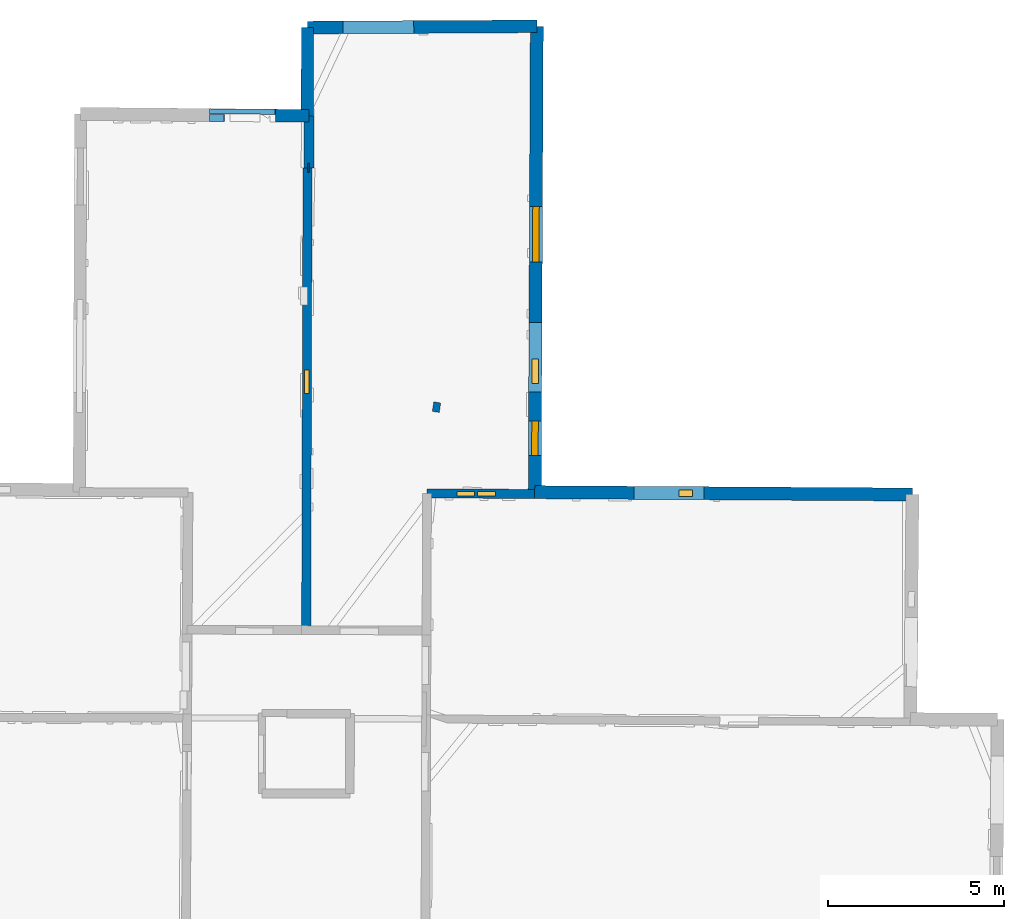
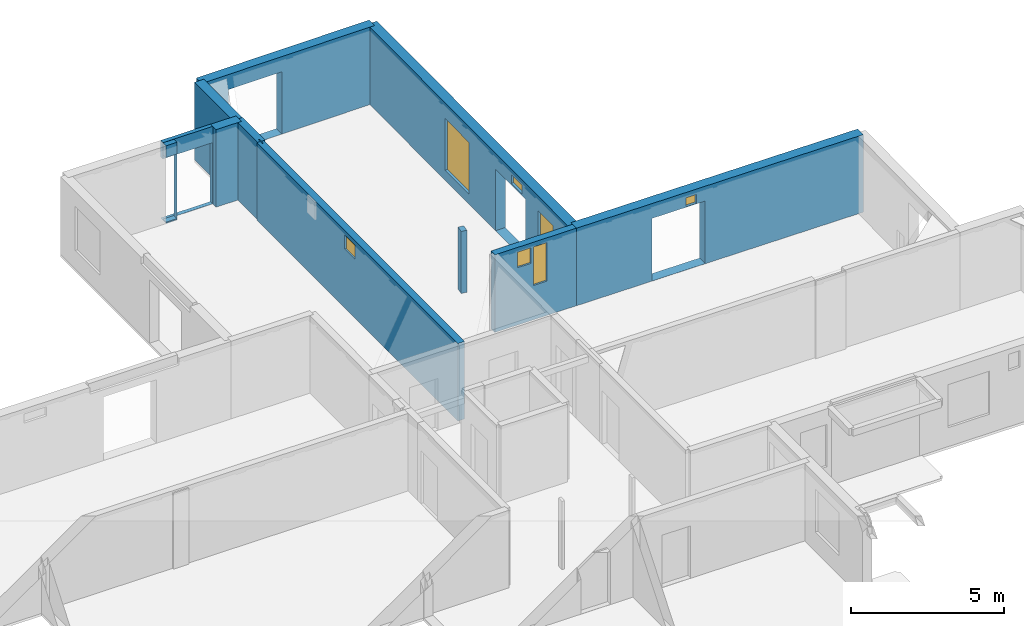
# One storey, part 10 of 15: 12 walls, 7 windows, 12 openings.
"""IFC2X3 building model written with IfcOpenShell, lengths in metres."""

from ifc_helpers import new_model, entity, si_unit, converted_unit, derived_unit, direction, frame, frame_2d, origin, origin_2d_with_axis, place, context, subcontext, project, spatial, polyline, rectangle, outline, extrude, source, transform, mapped, material, layer, layer_set, layer_usage, type_object, type_shapes, element, fill, save


model = new_model("IFC2X3")

# Units and contexts
model_context = context("Model", 3, precision=1e-05, world=origin(), true_north=direction((0.0, 1.0)))
body_context = subcontext(model_context, "Body", "Model", "MODEL_VIEW")
ifc_project = project(units=[si_unit("LENGTHUNIT", "METRE"), si_unit("AREAUNIT", "SQUARE_METRE"), si_unit("VOLUMEUNIT", "CUBIC_METRE"), converted_unit("PLANEANGLEUNIT", "DEGREE", entity("IfcRatioMeasure", 0.0174532925199433), si_unit("PLANEANGLEUNIT", "RADIAN"), dimensions=[0, 0, 0, 0, 0, 0, 0]), si_unit("MASSUNIT", "GRAM", prefix="KILO"), derived_unit("MASSDENSITYUNIT", [(si_unit("MASSUNIT", "GRAM", prefix="KILO"), 1), (si_unit("LENGTHUNIT", "METRE"), -3)]), derived_unit("MOMENTOFINERTIAUNIT", [(si_unit("LENGTHUNIT", "METRE"), 4)]), si_unit("TIMEUNIT", "SECOND"), si_unit("FREQUENCYUNIT", "HERTZ"), si_unit("THERMODYNAMICTEMPERATUREUNIT", "DEGREE_CELSIUS"), derived_unit("THERMALTRANSMITTANCEUNIT", [(si_unit("MASSUNIT", "GRAM", prefix="KILO"), 1), (si_unit("THERMODYNAMICTEMPERATUREUNIT", "KELVIN"), -1), (si_unit("TIMEUNIT", "SECOND"), -3)]), derived_unit("VOLUMETRICFLOWRATEUNIT", [(si_unit("LENGTHUNIT", "METRE"), 3), (si_unit("TIMEUNIT", "SECOND"), -1)]), si_unit("ELECTRICCURRENTUNIT", "AMPERE"), si_unit("ELECTRICVOLTAGEUNIT", "VOLT"), si_unit("POWERUNIT", "WATT"), si_unit("FORCEUNIT", "NEWTON", prefix="KILO"), si_unit("ILLUMINANCEUNIT", "LUX"), si_unit("LUMINOUSFLUXUNIT", "LUMEN"), si_unit("LUMINOUSINTENSITYUNIT", "CANDELA"), derived_unit("USERDEFINED", [(si_unit("MASSUNIT", "GRAM", prefix="KILO"), -1), (si_unit("LENGTHUNIT", "METRE"), -2), (si_unit("TIMEUNIT", "SECOND"), 3), (si_unit("LUMINOUSFLUXUNIT", "LUMEN"), 1)]), derived_unit("LINEARVELOCITYUNIT", [(si_unit("LENGTHUNIT", "METRE"), 1), (si_unit("TIMEUNIT", "SECOND"), -1)]), si_unit("PRESSUREUNIT", "PASCAL"), derived_unit("USERDEFINED", [(si_unit("LENGTHUNIT", "METRE"), -2), (si_unit("MASSUNIT", "GRAM", prefix="KILO"), 1), (si_unit("TIMEUNIT", "SECOND"), -2)]), derived_unit("LINEARFORCEUNIT", [(si_unit("MASSUNIT", "GRAM", prefix="KILO"), 1), (si_unit("LENGTHUNIT", "METRE"), 1), (si_unit("TIMEUNIT", "SECOND"), -2), (si_unit("LENGTHUNIT", "METRE"), -1)]), derived_unit("PLANARFORCEUNIT", [(si_unit("MASSUNIT", "GRAM", prefix="KILO"), 1), (si_unit("LENGTHUNIT", "METRE"), 1), (si_unit("TIMEUNIT", "SECOND"), -2), (si_unit("LENGTHUNIT", "METRE"), -2)])], contexts=[model_context])

# Site, building, storey
placement = place(None, origin())
site = spatial("IfcSite", under=ifc_project, at=placement, CompositionType="ELEMENT")
building = spatial("IfcBuilding", under=site, at=placement, CompositionType="ELEMENT")
storey_placement = place(placement, frame((0.0, 0.0, 2.3807327747345)))
storey = spatial("IfcBuildingStorey", under=building, at=storey_placement, Name="Level 2", CompositionType="ELEMENT", Elevation=2.3807327747345)

# Walls
ifc_material_1 = material(Name="Default wall")
ifc_layer_1 = layer(ifc_material_1, 0.349999994039536)
ifc_layer_set_1 = layer_set([ifc_layer_1], Name="wall_thickness_0.3500")
ifc_layer_usage_1 = layer_usage(ifc_layer_set_1, "AXIS2", "POSITIVE", -0.174999997019768)
wall_type_1 = type_object("IfcWallType", Name="wall_thickness_0.3500", PredefinedType="STANDARD", material=ifc_layer_set_1)
wall_1_placement = place(storey_placement, frame((6.40940972931042, 77.3030264539157, 0.0), z_axis=(0.0, 0.0, 1.0), x_axis=(-0.00343193730267941, -0.999994110885834, 0.0)))
element("IfcWallStandardCase", 1, at=wall_1_placement, inside=storey, type_object=wall_type_1, material=ifc_layer_usage_1, Name="Wall:833", ObjectType="Wall", context=body_context, shape_type="SweptSolid", body=[
    extrude(outline(polyline([(2.5126109274237, -0.174999997019768), (2.5126109274237, 0.174999997019768), (0.0, 0.174999997019768), (0.0, -0.174999997019768), (2.5126109274237, -0.174999997019768)])), origin(), (0.0, 0.0, 1.0), 3.08589615821838),
])
ifc_layer_2 = layer(ifc_material_1, 0.2)
ifc_layer_set_2 = layer_set([ifc_layer_2], Name="wall_thickness_0.2000")
ifc_layer_usage_2 = layer_usage(ifc_layer_set_2, "AXIS2", "POSITIVE", -0.1)
wall_type_2 = type_object("IfcWallType", Name="wall_thickness_0.2000", PredefinedType="STANDARD", material=ifc_layer_set_2)
wall_2_placement = place(storey_placement, frame((10.1019511417973, 66.6321647262947, 0.0), z_axis=(0.0, 0.0, 1.0), x_axis=(-0.144798683260253, -0.989461136844746, 0.0)))
element("IfcWallStandardCase", 2, at=wall_2_placement, inside=storey, type_object=wall_type_2, material=ifc_layer_usage_2, Name="Wall:792", ObjectType="Wall", context=body_context, shape_type="SweptSolid", body=[
    extrude(outline(polyline([(0.27500054911174, -0.1), (0.27500054911174, 0.1), (0.0, 0.1), (0.0, -0.1), (0.27500054911174, -0.1)])), origin(), (0.0, 0.0, 1.0), 2.46726727485657),
])

# Wall, opening, window
ifc_layer_3 = layer(ifc_material_1, 0.259999990463257)
ifc_layer_set_3 = layer_set([ifc_layer_3], Name="wall_thickness_0.2600")
ifc_layer_usage_3 = layer_usage(ifc_layer_set_3, "AXIS2", "POSITIVE", -0.129999995231628)
wall_type_3 = type_object("IfcWallType", Name="wall_thickness_0.2600", PredefinedType="STANDARD", material=ifc_layer_set_3)
wall_3_placement = place(storey_placement, frame((6.40879468991422, 73.3114207593688, 0.0), z_axis=(0.0, 0.0, 1.0), x_axis=(-0.00290263283017364, -0.999995787352453, 0.0)))
wall_3 = element("IfcWallStandardCase", 3, at=wall_3_placement, inside=storey, type_object=wall_type_3, material=ifc_layer_usage_3, Name="Wall:713", ObjectType="Wall", context=body_context, shape_type="SweptSolid", body=[
    extrude(outline(polyline([(13.163717410889, -0.129999995231628), (13.163717410889, 0.129999995231628), (0.0, 0.129999995231628), (0.0, -0.129999995231628), (13.163717410889, -0.129999995231628)])), origin(), (0.0, 0.0, 1.0), 3.08589615821838),
])
opening_1_placement = place(wall_3_placement, frame((5.75252668050183, -0.129999995231628, 2.3502676486969)))
opening_1 = element("IfcOpeningElement", 4, at=opening_1_placement, cuts=wall_3, Name="Opening : 675 x 570 : 454", ObjectType="Opening", context=body_context, shape_type="SweptSolid", body=[
    extrude(rectangle(XDim=0.675, YDim=0.57, at=frame_2d((0.285, 0.3375), x_axis=(0.0, 1.0))), frame((0.0, 0.0, 0.0), z_axis=(0.0, 1.0, 0.0), x_axis=(0.0, 0.0, 1.0)), (0.0, 0.0, 1.0), 0.259999990463257),
])
ifc_material_2 = material(Name="Window Default")
window_style_1 = type_object("IfcWindowStyle", Name="Window : 675 x 570mm", ConstructionType="NOTDEFINED", OperationType="NOTDEFINED", ParameterTakesPrecedence=False, Sizeable=False, material=ifc_material_2)
shared_shape_1 = source(origin(), body_context, "Body", "SweptSolid", [
    extrude(rectangle(XDim=0.129999995231628, YDim=0.675, at=origin_2d_with_axis()), frame((0.3375, 0.129999995231628, 0.0), z_axis=(0.0, 0.0, 1.0), x_axis=(0.0, 1.0, 0.0)), (0.0, 0.0, 1.0), 0.57),
])
type_shapes(window_style_1, [shared_shape_1])
window_1_placement = place(opening_1_placement, origin())
window_1 = element("IfcWindow", 5, at=window_1_placement, inside=storey, type_object=window_style_1, Name="Window : 675 x 570mm : 247", ObjectType="Window : 675 x 570mm", OverallHeight=0.57, OverallWidth=0.675, context=body_context, shape_type="MappedRepresentation", body=[
    mapped(shared_shape_1, transform((0.0, 0.0, 0.0), scale=1.0)),
])
fill(opening_1, window_1)

# Wall, openings, windows
wall_4_placement = place(storey_placement, frame((9.81067877445257, 64.0406864352747, 0.0), z_axis=(0.0, 0.0, 1.0), x_axis=(0.999987550143293, -0.00498994573263831, 0.0)))
wall_4 = element("IfcWallStandardCase", 6, at=wall_4_placement, inside=storey, type_object=wall_type_3, material=ifc_layer_usage_3, Name="Wall:818", ObjectType="Wall", context=body_context, shape_type="SweptSolid", body=[
    extrude(outline(polyline([(3.06708053548222, -0.129999995231628), (3.06708053548222, 0.129999995231628), (0.0, 0.129999995231628), (0.0, -0.129999995231628), (3.06708053548222, -0.129999995231628)])), origin(), (0.0, 0.0, 1.0), 3.08589615821838),
])
opening_2_placement = place(wall_4_placement, frame((0.85747689298459, -0.129999995231628, 2.27726721763611)))
opening_2 = element("IfcOpeningElement", 7, at=opening_2_placement, cuts=wall_4, Name="Opening : 495 x 620 : 521", ObjectType="Opening", context=body_context, shape_type="SweptSolid", body=[
    extrude(rectangle(XDim=0.495, YDim=0.62, at=frame_2d((0.31, 0.2475), x_axis=(0.0, 1.0))), frame((0.0, 0.0, 0.0), z_axis=(0.0, 1.0, 0.0), x_axis=(0.0, 0.0, 1.0)), (0.0, 0.0, 1.0), 0.259999990463257),
])
opening_3_placement = place(wall_4_placement, frame((1.44247278492697, -0.129999995231628, 1.36226773262024)))
opening_3 = element("IfcOpeningElement", 8, at=opening_3_placement, cuts=wall_4, Name="Opening : 505 x 1535 : 522", ObjectType="Opening", context=body_context, shape_type="SweptSolid", body=[
    extrude(rectangle(XDim=0.505, YDim=1.535, at=frame_2d((0.7675, 0.2525), x_axis=(0.0, 1.0))), frame((0.0, 0.0, 0.0), z_axis=(0.0, 1.0, 0.0), x_axis=(0.0, 0.0, 1.0)), (0.0, 0.0, 1.0), 0.259999990463257),
])
window_style_2 = type_object("IfcWindowStyle", Name="Window : 495 x 620mm", ConstructionType="NOTDEFINED", OperationType="NOTDEFINED", ParameterTakesPrecedence=False, Sizeable=False, material=ifc_material_2)
shared_shape_2 = source(origin(), body_context, "Body", "SweptSolid", [
    extrude(rectangle(XDim=0.129999995231628, YDim=0.495, at=origin_2d_with_axis()), frame((0.2475, 0.129999995231628, 0.0), z_axis=(0.0, 0.0, 1.0), x_axis=(0.0, 1.0, 0.0)), (0.0, 0.0, 1.0), 0.62),
])
type_shapes(window_style_2, [shared_shape_2])
window_2_placement = place(opening_2_placement, origin())
window_2 = element("IfcWindow", 9, at=window_2_placement, inside=storey, type_object=window_style_2, Name="Window : 495 x 620mm : 279", ObjectType="Window : 495 x 620mm", OverallHeight=0.62, OverallWidth=0.495, context=body_context, shape_type="MappedRepresentation", body=[
    mapped(shared_shape_2, transform((0.0, 0.0, 0.0), scale=1.0)),
])
fill(opening_2, window_2)
window_style_3 = type_object("IfcWindowStyle", Name="Window : 505 x 1535mm", ConstructionType="NOTDEFINED", OperationType="NOTDEFINED", ParameterTakesPrecedence=False, Sizeable=False, material=ifc_material_2)
shared_shape_3 = source(origin(), body_context, "Body", "SweptSolid", [
    extrude(rectangle(XDim=0.129999995231628, YDim=0.505, at=origin_2d_with_axis()), frame((0.2525, 0.129999995231628, 0.0), z_axis=(0.0, 0.0, 1.0), x_axis=(0.0, 1.0, 0.0)), (0.0, 0.0, 1.0), 1.535),
])
type_shapes(window_style_3, [shared_shape_3])
window_3_placement = place(opening_3_placement, origin())
window_3 = element("IfcWindow", 10, at=window_3_placement, inside=storey, type_object=window_style_3, Name="Window : 505 x 1535mm : 280", ObjectType="Window : 505 x 1535mm", OverallHeight=1.535, OverallWidth=0.505, context=body_context, shape_type="MappedRepresentation", body=[
    mapped(shared_shape_3, transform((0.0, 0.0, 0.0), scale=1.0)),
])
fill(opening_3, window_3)

ifc_layer_4 = layer(ifc_material_1, 0.370000004768372)
ifc_layer_set_4 = layer_set([ifc_layer_4], Name="wall_thickness_0.3700")
ifc_layer_usage_4 = layer_usage(ifc_layer_set_4, "AXIS2", "POSITIVE", -0.185000002384186)
wall_type_4 = type_object("IfcWallType", Name="wall_thickness_0.3700", PredefinedType="STANDARD", material=ifc_layer_set_4)
wall_5_placement = place(storey_placement, frame((12.9374793923585, 77.3395143958828, 0.0), z_axis=(0.0, 0.0, 1.0), x_axis=(-0.00448835509401027, -0.999989927283545, 0.0)))
wall_5 = element("IfcWallStandardCase", 11, at=wall_5_placement, inside=storey, type_object=wall_type_4, material=ifc_layer_usage_4, Name="Wall:689", ObjectType="Wall", context=body_context, shape_type="SweptSolid", body=[
    extrude(outline(polyline([(13.2641182858783, -0.185000002384186), (13.2641182858783, 0.185000002384186), (0.0, 0.185000002384186), (0.0, -0.185000002384186), (13.2641182858783, -0.185000002384186)])), origin(), (0.0, 0.0, 1.0), 3.08589615821838),
])
opening_4_placement = place(wall_5_placement, frame((8.43811901623632, -0.185000002384186, 0.00526785850524902)))
element("IfcOpeningElement", 12, at=opening_4_placement, cuts=wall_5, Name="Opening : 1975 x 2450 : 434", ObjectType="Opening", context=body_context, shape_type="SweptSolid", body=[
    extrude(rectangle(XDim=1.975, YDim=2.45, at=frame_2d((1.225, 0.9875), x_axis=(0.0, 1.0))), frame((0.0, 0.0, 0.0), z_axis=(0.0, 1.0, 0.0), x_axis=(0.0, 0.0, 1.0)), (0.0, 0.0, 1.0), 0.370000004768372),
])
opening_5_placement = place(wall_5_placement, frame((5.13312357018762, -0.185000002384186, 0.400267839431763)))
opening_5 = element("IfcOpeningElement", 13, at=opening_5_placement, cuts=wall_5, Name="Opening : 1580 x 2055 : 435", ObjectType="Opening", context=body_context, shape_type="SweptSolid", body=[
    extrude(rectangle(XDim=1.58, YDim=2.055, at=frame_2d((1.0275, 0.79), x_axis=(0.0, 1.0))), frame((0.0, 0.0, 0.0), z_axis=(0.0, 1.0, 0.0), x_axis=(0.0, 0.0, 1.0)), (0.0, 0.0, 1.0), 0.370000004768372),
])
opening_6_placement = place(wall_5_placement, frame((9.47597126912073, -0.185000002384186, 2.5212676525116)))
opening_6 = element("IfcOpeningElement", 14, at=opening_6_placement, cuts=wall_5, Name="Opening : 695 x 350 : 436", ObjectType="Opening", context=body_context, shape_type="SweptSolid", body=[
    extrude(rectangle(XDim=0.695, YDim=0.35, at=frame_2d((0.175, 0.3475), x_axis=(0.0, 1.0))), frame((0.0, 0.0, 0.0), z_axis=(0.0, 1.0, 0.0), x_axis=(0.0, 0.0, 1.0)), (0.0, 0.0, 1.0), 0.370000004768372),
])
opening_7_placement = place(wall_5_placement, frame((11.2381197545796, -0.185000002384186, 0.755267858505249)))
opening_7 = element("IfcOpeningElement", 15, at=opening_7_placement, cuts=wall_5, Name="Opening : 980 x 1745 : 437", ObjectType="Opening", context=body_context, shape_type="SweptSolid", body=[
    extrude(rectangle(XDim=0.98, YDim=1.745, at=frame_2d((0.8725, 0.49), x_axis=(0.0, 1.0))), frame((0.0, 0.0, 0.0), z_axis=(0.0, 1.0, 0.0), x_axis=(0.0, 0.0, 1.0)), (0.0, 0.0, 1.0), 0.370000004768372),
])
window_style_4 = type_object("IfcWindowStyle", Name="Window : 1580 x 2055mm", ConstructionType="NOTDEFINED", OperationType="NOTDEFINED", ParameterTakesPrecedence=False, Sizeable=False, material=ifc_material_2)
shared_shape_4 = source(origin(), body_context, "Body", "SweptSolid", [
    extrude(rectangle(XDim=0.185000002384186, YDim=1.58, at=origin_2d_with_axis()), frame((0.79, 0.185000002384186, 0.0), z_axis=(0.0, 0.0, 1.0), x_axis=(0.0, 1.0, 0.0)), (0.0, 0.0, 1.0), 2.055),
])
type_shapes(window_style_4, [shared_shape_4])
window_4_placement = place(opening_5_placement, origin())
window_4 = element("IfcWindow", 16, at=window_4_placement, inside=storey, type_object=window_style_4, Name="Window : 1580 x 2055mm : 236", ObjectType="Window : 1580 x 2055mm", OverallHeight=2.055, OverallWidth=1.58, context=body_context, shape_type="MappedRepresentation", body=[
    mapped(shared_shape_4, transform((0.0, 0.0, 0.0), scale=1.0)),
])
fill(opening_5, window_4)
window_style_5 = type_object("IfcWindowStyle", Name="Window : 695 x 350mm", ConstructionType="NOTDEFINED", OperationType="NOTDEFINED", ParameterTakesPrecedence=False, Sizeable=False, material=ifc_material_2)
shared_shape_5 = source(origin(), body_context, "Body", "SweptSolid", [
    extrude(rectangle(XDim=0.185000002384186, YDim=0.695, at=origin_2d_with_axis()), frame((0.3475, 0.185000002384186, 0.0), z_axis=(0.0, 0.0, 1.0), x_axis=(0.0, 1.0, 0.0)), (0.0, 0.0, 1.0), 0.35),
])
type_shapes(window_style_5, [shared_shape_5])
window_5_placement = place(opening_6_placement, origin())
window_5 = element("IfcWindow", 17, at=window_5_placement, inside=storey, type_object=window_style_5, Name="Window : 695 x 350mm : 237", ObjectType="Window : 695 x 350mm", OverallHeight=0.35, OverallWidth=0.695, context=body_context, shape_type="MappedRepresentation", body=[
    mapped(shared_shape_5, transform((0.0, 0.0, 0.0), scale=1.0)),
])
fill(opening_6, window_5)
window_style_6 = type_object("IfcWindowStyle", Name="Window : 980 x 1745mm", ConstructionType="NOTDEFINED", OperationType="NOTDEFINED", ParameterTakesPrecedence=False, Sizeable=False, material=ifc_material_2)
shared_shape_6 = source(origin(), body_context, "Body", "SweptSolid", [
    extrude(rectangle(XDim=0.185000002384186, YDim=0.98, at=origin_2d_with_axis()), frame((0.49, 0.185000002384186, 0.0), z_axis=(0.0, 0.0, 1.0), x_axis=(0.0, 1.0, 0.0)), (0.0, 0.0, 1.0), 1.745),
])
type_shapes(window_style_6, [shared_shape_6])
window_6_placement = place(opening_7_placement, origin())
window_6 = element("IfcWindow", 18, at=window_6_placement, inside=storey, type_object=window_style_6, Name="Window : 980 x 1745mm : 238", ObjectType="Window : 980 x 1745mm", OverallHeight=1.745, OverallWidth=0.98, context=body_context, shape_type="MappedRepresentation", body=[
    mapped(shared_shape_6, transform((0.0, 0.0, 0.0), scale=1.0)),
])
fill(opening_7, window_6)

# Wall, openings, window
wall_6_placement = place(storey_placement, frame((12.877946214726, 64.0755243825008, 0.0), z_axis=(0.0, 0.0, 1.0), x_axis=(0.999981333837981, -0.00610998982099564, 0.0)))
wall_6 = element("IfcWallStandardCase", 19, at=wall_6_placement, inside=storey, type_object=wall_type_4, material=ifc_layer_usage_4, Name="Wall:744", ObjectType="Wall", context=body_context, shape_type="SweptSolid", body=[
    extrude(outline(polyline([(10.7560906675092, -0.185000002384186), (10.7560906675092, 0.185000002384186), (0.0, 0.185000002384186), (0.0, -0.185000002384186), (10.7560906675092, -0.185000002384186)])), origin(), (0.0, 0.0, 1.0), 3.08589615821838),
])
opening_8_placement = place(wall_6_placement, frame((2.83135872644537, -0.185000002384186, 0.00526785850524902)))
element("IfcOpeningElement", 20, at=opening_8_placement, cuts=wall_6, Name="Opening : 1990 x 2490 : 477", ObjectType="Opening", context=body_context, shape_type="SweptSolid", body=[
    extrude(rectangle(XDim=1.99, YDim=2.49, at=frame_2d((1.245, 0.995), x_axis=(0.0, 1.0))), frame((0.0, 0.0, 0.0), z_axis=(0.0, 1.0, 0.0), x_axis=(0.0, 0.0, 1.0)), (0.0, 0.0, 1.0), 0.370000004768372),
])
opening_9_placement = place(wall_6_placement, frame((4.10189599998212, -0.185000002384186, 2.52126717567444)))
opening_9 = element("IfcOpeningElement", 21, at=opening_9_placement, cuts=wall_6, Name="Opening : 395 x 350 : 478", ObjectType="Opening", context=body_context, shape_type="SweptSolid", body=[
    extrude(rectangle(XDim=0.395, YDim=0.35, at=frame_2d((0.175, 0.1975), x_axis=(0.0, 1.0))), frame((0.0, 0.0, 0.0), z_axis=(0.0, 1.0, 0.0), x_axis=(0.0, 0.0, 1.0)), (0.0, 0.0, 1.0), 0.370000004768372),
])
window_style_7 = type_object("IfcWindowStyle", Name="Window : 395 x 350mm", ConstructionType="NOTDEFINED", OperationType="NOTDEFINED", ParameterTakesPrecedence=False, Sizeable=False, material=ifc_material_2)
shared_shape_7 = source(origin(), body_context, "Body", "SweptSolid", [
    extrude(rectangle(XDim=0.185000002384186, YDim=0.395, at=origin_2d_with_axis()), frame((0.1975, 0.185000002384186, 0.0), z_axis=(0.0, 0.0, 1.0), x_axis=(0.0, 1.0, 0.0)), (0.0, 0.0, 1.0), 0.35),
])
type_shapes(window_style_7, [shared_shape_7])
window_7_placement = place(opening_9_placement, origin())
window_7 = element("IfcWindow", 22, at=window_7_placement, inside=storey, type_object=window_style_7, Name="Window : 395 x 350mm : 259", ObjectType="Window : 395 x 350mm", OverallHeight=0.35, OverallWidth=0.395, context=body_context, shape_type="MappedRepresentation", body=[
    mapped(shared_shape_7, transform((0.0, 0.0, 0.0), scale=1.0)),
])
fill(opening_9, window_7)

# Wall, opening
ifc_layer_5 = layer(ifc_material_1, 0.200000002980232)
ifc_layer_set_5 = layer_set([ifc_layer_5], Name="wall_thickness_0.2000")
ifc_layer_usage_5 = layer_usage(ifc_layer_set_5, "AXIS2", "POSITIVE", -0.100000001490116)
wall_type_5 = type_object("IfcWallType", Name="wall_thickness_0.2000", PredefinedType="STANDARD", material=ifc_layer_set_5)
wall_7_placement = place(storey_placement, frame((3.62370016399202, 74.7358173775666, 0.0), z_axis=(0.0, 0.0, 1.0), x_axis=(0.999988906632864, -0.00471026657526411, 0.0)))
wall_7 = element("IfcWallStandardCase", 23, at=wall_7_placement, inside=storey, type_object=wall_type_5, material=ifc_layer_usage_5, Name="Wall:703", ObjectType="Wall", context=body_context, shape_type="SweptSolid", body=[
    extrude(outline(polyline([(0.416272489720247, -0.100000001490116), (0.416272489720247, 0.100000001490116), (0.0, 0.100000001490116), (0.0, -0.100000001490116), (0.416272489720247, -0.100000001490116)])), origin(), (0.0, 0.0, 1.0), 3.08589615821838),
])
opening_10_placement = place(wall_7_placement, frame((-0.293727416686131, -0.100000001490116, 0.0502669811248779)))
element("IfcOpeningElement", 24, at=opening_10_placement, cuts=wall_7, Name="Opening : 705 x 2570 : 444", ObjectType="Opening", context=body_context, shape_type="SweptSolid", body=[
    extrude(rectangle(XDim=0.705, YDim=2.57, at=frame_2d((1.285, 0.3525), x_axis=(0.0, 1.0))), frame((0.0, 0.0, 0.0), z_axis=(0.0, 1.0, 0.0), x_axis=(0.0, 0.0, 1.0)), (0.0, 0.0, 1.0), 0.200000002980232),
])

ifc_layer_6 = layer(ifc_material_1, 0.360000014305115)
ifc_layer_set_6 = layer_set([ifc_layer_6], Name="wall_thickness_0.3600")
ifc_layer_usage_6 = layer_usage(ifc_layer_set_6, "AXIS2", "POSITIVE", -0.180000007152557)
wall_type_6 = type_object("IfcWallType", Name="wall_thickness_0.3600", PredefinedType="STANDARD", material=ifc_layer_set_6)
wall_8_placement = place(storey_placement, frame((6.40940885447286, 77.303035030278, 0.0), z_axis=(0.0, 0.0, 1.0), x_axis=(0.999984383286354, 0.00558866561979852, 0.0)))
wall_8 = element("IfcWallStandardCase", 25, at=wall_8_placement, inside=storey, type_object=wall_type_6, material=ifc_layer_usage_6, Name="Wall:775", ObjectType="Wall", context=body_context, shape_type="SweptSolid", body=[
    extrude(outline(polyline([(6.52817096789426, -0.180000007152557), (6.52817096789426, 0.180000007152557), (0.0, 0.180000007152557), (0.0, -0.180000007152557), (6.52817096789426, -0.180000007152557)])), origin(), (0.0, 0.0, 1.0), 3.08589615821838),
])
opening_11_placement = place(wall_8_placement, frame((1.00414747691466, -0.180000007152557, 0.00526785850524902)))
element("IfcOpeningElement", 26, at=opening_11_placement, cuts=wall_8, Name="Opening : 2020 x 2480 : 489", ObjectType="Opening", context=body_context, shape_type="SweptSolid", body=[
    extrude(rectangle(XDim=2.02, YDim=2.48, at=frame_2d((1.24, 1.01), x_axis=(0.0, 1.0))), frame((0.0, 0.0, 0.0), z_axis=(0.0, 1.0, 0.0), x_axis=(0.0, 0.0, 1.0)), (0.0, 0.0, 1.0), 0.360000014305115),
])

# Wall
wall_9_placement = place(storey_placement, frame((5.49723104782976, 74.7988744400063, 0.0), z_axis=(0.0, 0.0, 1.0), x_axis=(0.999956402201162, -0.00933775652433995, 0.0)))
element("IfcWallStandardCase", 27, at=wall_9_placement, inside=storey, type_object=wall_type_6, material=ifc_layer_usage_6, Name="Wall:777", ObjectType="Wall", context=body_context, shape_type="SweptSolid", body=[
    extrude(outline(polyline([(0.954311968755246, -0.180000007152557), (0.954311968755246, 0.180000007152557), (0.0, 0.180000007152557), (0.0, -0.180000007152557), (0.954311968755246, -0.180000007152557)])), origin(), (0.0, 0.0, 1.0), 3.08589615821838),
])

# Wall, opening
ifc_layer_7 = layer(ifc_material_1, 0.150000005960464)
ifc_layer_set_7 = layer_set([ifc_layer_7], Name="wall_thickness_0.1500")
ifc_layer_usage_7 = layer_usage(ifc_layer_set_7, "AXIS2", "POSITIVE", -0.0750000029802322)
wall_type_7 = type_object("IfcWallType", Name="wall_thickness_0.1500", PredefinedType="STANDARD", material=ifc_layer_set_7)
wall_10_placement = place(storey_placement, frame((3.62455987789292, 74.9177955053171, 0.0), z_axis=(0.0, 0.0, 1.0), x_axis=(0.999989021529408, -0.00468581056570425, 0.0)))
wall_10 = element("IfcWallStandardCase", 28, at=wall_10_placement, inside=storey, type_object=wall_type_7, material=ifc_layer_usage_7, Name="Wall:766", ObjectType="Wall", context=body_context, shape_type="SweptSolid", body=[
    extrude(outline(polyline([(1.87404782637622, -0.0750000029802322), (1.87404782637622, 0.0750000029802322), (0.0, 0.0750000029802322), (0.0, -0.0750000029802322), (1.87404782637622, -0.0750000029802322)])), origin(), (0.0, 0.0, 1.0), 3.08589615821838),
])
opening_12_placement = place(wall_10_placement, frame((-0.119689321577622, -0.0750000029802322, 0.00526785850524902)))
element("IfcOpeningElement", 29, at=opening_12_placement, cuts=wall_10, Name="Opening : 1980 x 2435 : 486", ObjectType="Opening", context=body_context, shape_type="SweptSolid", body=[
    extrude(rectangle(XDim=1.98, YDim=2.435, at=frame_2d((1.2175, 0.99), x_axis=(0.0, 1.0))), frame((0.0, 0.0, 0.0), z_axis=(0.0, 1.0, 0.0), x_axis=(0.0, 0.0, 1.0)), (0.0, 0.0, 1.0), 0.150000005960464),
])

# Walls
ifc_layer_8 = layer(ifc_material_1, 0.245675176382065)
ifc_layer_set_8 = layer_set([ifc_layer_8], Name="wall_thickness_0.2457")
ifc_layer_usage_8 = layer_usage(ifc_layer_set_8, "AXIS2", "POSITIVE", -0.122837588191032)
wall_type_8 = type_object("IfcWallType", Name="wall_thickness_0.2457", PredefinedType="STANDARD", material=ifc_layer_set_8)
wall_11_placement = place(storey_placement, frame((6.40879464148086, 73.3114280656607, 0.0), z_axis=(0.0, 0.0, 1.0), x_axis=(0.99999541734671, -0.00302742226632873, 0.0)))
element("IfcWallStandardCase", 30, at=wall_11_placement, inside=storey, type_object=wall_type_8, material=ifc_layer_usage_8, Name="Wall:712", ObjectType="Wall", context=body_context, shape_type="SweptSolid", body=[
    extrude(outline(polyline([(0.0428416308071001, -0.122837588191032), (0.0428416308071001, 0.122837588191032), (0.0, 0.122837588191032), (0.0, -0.122837588191032), (0.0428416308071001, -0.122837588191032)])), origin(), (0.0, 0.0, 1.0), 3.08589615821838),
])
ifc_layer_9 = layer(ifc_material_1, 0.280000001192093)
ifc_layer_set_9 = layer_set([ifc_layer_9], Name="wall_thickness_0.2800")
ifc_layer_usage_9 = layer_usage(ifc_layer_set_9, "AXIS2", "POSITIVE", -0.140000000596046)
wall_type_9 = type_object("IfcWallType", Name="wall_thickness_0.2800", PredefinedType="STANDARD", material=ifc_layer_set_9)
wall_12_placement = place(storey_placement, frame((6.45150054932911, 74.7899602900386, 0.0), z_axis=(0.0, 0.0, 1.0), x_axis=(9.09395796249964e-05, -0.999999995864996, 0.0)))
element("IfcWallStandardCase", 31, at=wall_12_placement, inside=storey, type_object=wall_type_9, material=ifc_layer_usage_9, Name="Wall:728", ObjectType="Wall", context=body_context, shape_type="SweptSolid", body=[
    extrude(outline(polyline([(1.4786529602158, -0.140000000596046), (1.4786529602158, 0.140000000596046), (0.0, 0.140000000596046), (0.0, -0.140000000596046), (1.4786529602158, -0.140000000596046)])), origin(), (0.0, 0.0, 1.0), 3.08589615821838),
])

save(model, "model.ifc")
